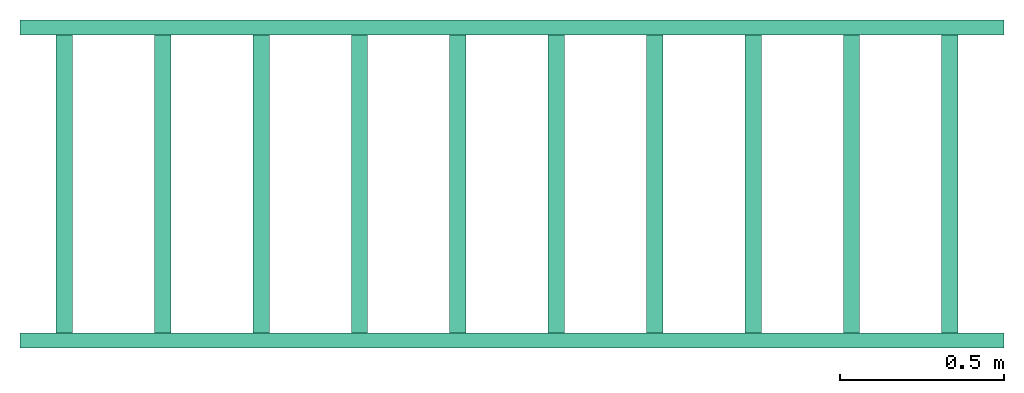
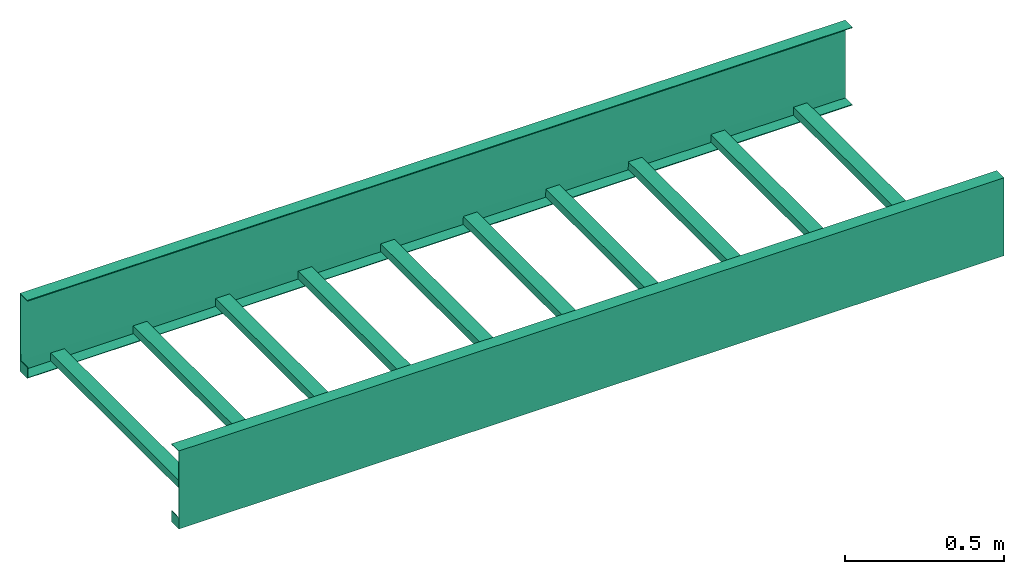
# One storey: 1 cable carrier segment.
"""IFC4 building model written with IfcOpenShell, lengths in millimetres."""

import ifcopenshell
import ifcopenshell.guid

model = None  # the IFC model being written
_history = None  # IfcOwnerHistory: only IFC2X3 demands one
_inside = {}  # id of a spatial element -> (the spatial element, [elements in it])
_under = {}  # id of a project, library or spatial element -> (it, [spatial elements below it])
_declared = {}  # id of a project -> (the project, [libraries it declares])
_typed = {}  # id of a type object -> (the type object, [elements of that type])
_made_of = {}  # id of a material, layer set ... -> (it, [elements and type objects made of it])


def new_model(schema):
    """Start an empty IFC model of exactly this schema.

    Asked for "IFC4X3", IfcOpenShell would pick the latest addendum, in which some entities
    have other attributes; the version numbers below select the first issue.
    IFC2X3 requires an IfcOwnerHistory on every rooted entity: one is made here for all.
    """
    global model, _history
    if schema == "IFC4X3":
        model = ifcopenshell.file(schema_version=(4, 3, 0, 0))
    else:
        model = ifcopenshell.file(schema=schema)
    _inside.clear()
    _under.clear()
    _declared.clear()
    _typed.clear()
    _made_of.clear()
    _history = None
    if model.schema == "IFC2X3":
        org = make("IfcOrganization", Name="unknown")
        user = make(
            "IfcPersonAndOrganization",
            ThePerson=make("IfcPerson", FamilyName="unknown"),
            TheOrganization=org,
        )
        app = make(
            "IfcApplication",
            ApplicationDeveloper=org,
            Version="unknown",
            ApplicationFullName="unknown",
            ApplicationIdentifier="unknown",
        )
        _history = make(
            "IfcOwnerHistory",
            OwningUser=user,
            OwningApplication=app,
            ChangeAction="ADDED",
            CreationDate=0,
        )
    return model


def make(cls, **values):
    """One entity of the class cls with the attributes given. An attribute that is None is left unset."""
    return model.create_entity(
        cls, **{name: value for name, value in values.items() if value is not None}
    )


def entity(cls, *values):
    """Any entity or typed value of the class cls, its attributes in the order of the schema. None: left unset."""
    e = model.create_entity(cls)
    for i, value in enumerate(values):
        if value is not None:
            e[i] = value
    return e


def rooted(cls, **values):
    """An entity with a GlobalId (a new one), such as an element, a storey or a relation."""
    return make(cls, GlobalId=ifcopenshell.guid.new(), OwnerHistory=_history, **values)


def si_unit(unit_type, name, prefix=None):
    """IfcSIUnit, for example si_unit("LENGTHUNIT", "METRE", prefix="MILLI")."""
    return make("IfcSIUnit", UnitType=unit_type, Prefix=prefix, Name=name)


def converted_unit(unit_type, name, factor, base, dimensions=None, offset=None):
    """IfcConversionBasedUnit, such as the inch: factor (a typed value) times the base unit."""
    return make(
        "IfcConversionBasedUnit"
        if offset is None
        else "IfcConversionBasedUnitWithOffset",
        ConversionOffset=offset,
        Dimensions=None
        if dimensions is None
        else entity("IfcDimensionalExponents", *dimensions),
        UnitType=unit_type,
        Name=name,
        ConversionFactor=make(
            "IfcMeasureWithUnit", ValueComponent=factor, UnitComponent=base
        ),
    )


def assignment(units):
    """IfcUnitAssignment: the units of a project."""
    return None if units is None else make("IfcUnitAssignment", Units=units)


def point(xyz):
    """IfcCartesianPoint."""
    return None if xyz is None else make("IfcCartesianPoint", Coordinates=xyz)


def direction(xyz):
    """IfcDirection."""
    return None if xyz is None else make("IfcDirection", DirectionRatios=xyz)


def frame(location, z_axis=None, x_axis=None):
    """IfcAxis2Placement3D, a coordinate frame: its origin and axes. An axis left out is left unset."""
    return make(
        "IfcAxis2Placement3D",
        Location=point(location),
        Axis=direction(z_axis),
        RefDirection=direction(x_axis),
    )


def frame_2d(location, x_axis=None):
    """IfcAxis2Placement2D, a coordinate frame in the plane: its origin and x axis."""
    return make(
        "IfcAxis2Placement2D", Location=point(location), RefDirection=direction(x_axis)
    )


def origin_with_axes():
    """The frame at (0, 0, 0) with the z axis (0, 0, 1) and the x axis (1, 0, 0) written out."""
    return frame((0.0, 0.0, 0.0), z_axis=(0.0, 0.0, 1.0), x_axis=(1.0, 0.0, 0.0))


def origin_2d_with_axis():
    """The frame at (0, 0) in the plane with the x axis (1, 0) written out."""
    return frame_2d((0.0, 0.0), x_axis=(1.0, 0.0))


def place(relative_to, where):
    """IfcLocalPlacement: puts the frame where relative to a parent placement (None: the world)."""
    return make(
        "IfcLocalPlacement", PlacementRelTo=relative_to, RelativePlacement=where
    )


def context(
    kind, dimensions, precision=None, world=None, true_north=None, identifier=None
):
    """IfcGeometricRepresentationContext, for example the 3D "Model" context."""
    return make(
        "IfcGeometricRepresentationContext",
        ContextIdentifier=identifier,
        ContextType=kind,
        CoordinateSpaceDimension=dimensions,
        Precision=precision,
        WorldCoordinateSystem=world,
        TrueNorth=true_north,
    )


def subcontext(parent, identifier, kind, view, scale=None):
    """IfcGeometricRepresentationSubContext, for example "Body" below "Model"."""
    return make(
        "IfcGeometricRepresentationSubContext",
        ContextIdentifier=identifier,
        ContextType=kind,
        ParentContext=parent,
        TargetScale=scale,
        TargetView=view,
    )


def project(units=None, contexts=None):
    """IfcProject with its units and contexts."""
    return rooted(
        "IfcProject",
        Name="project",
        RepresentationContexts=contexts,
        UnitsInContext=assignment(units),
    )


def spatial(cls, under=None, at=None, **own):
    """A site, building, storey or space (cls), placed at a placement, below another one or the project."""
    s = rooted(cls, ObjectPlacement=at, **own)
    if under is not None:
        _under.setdefault(under.id(), (under, []))[1].append(s)
    return s


def point_list(points):
    """IfcCartesianPointList2D or 3D."""
    cls = (
        "IfcCartesianPointList2D" if len(points[0]) == 2 else "IfcCartesianPointList3D"
    )
    return make(cls, CoordList=points)


def polygons(points, faces, closed=None, point_numbers=None):
    """IfcPolygonalFaceSet: a face is its outer loop, then its inner loops; points numbered from 1."""
    made = []
    for loops in faces:
        if len(loops) == 1:
            made.append(make("IfcIndexedPolygonalFace", CoordIndex=loops[0]))
        else:
            made.append(
                make(
                    "IfcIndexedPolygonalFaceWithVoids",
                    CoordIndex=loops[0],
                    InnerCoordIndices=loops[1:],
                )
            )
    return make(
        "IfcPolygonalFaceSet",
        Coordinates=point_list(points),
        Closed=closed,
        Faces=made,
        PnIndex=point_numbers,
    )


def shape(context_of_items, identifier, shape_type, items):
    """IfcShapeRepresentation: the items that make up one representation, for example the "Body"."""
    return make(
        "IfcShapeRepresentation",
        ContextOfItems=context_of_items,
        RepresentationIdentifier=identifier,
        RepresentationType=shape_type,
        Items=items,
    )


def source(mapping_origin, context_of_items, identifier, shape_type, items):
    """IfcRepresentationMap: a shape defined once, which mapped items show again and again."""
    return make(
        "IfcRepresentationMap",
        MappingOrigin=mapping_origin,
        MappedRepresentation=shape(context_of_items, identifier, shape_type, items),
    )


def transform(
    local_origin,
    x_axis=None,
    y_axis=None,
    z_axis=None,
    scale=None,
    scale2=None,
    scale3=None,
    uniform=True,
):
    """IfcCartesianTransformationOperator3D, or its non-uniform kind. x_axis, y_axis, z_axis: its Axis1, 2, 3."""
    if uniform:
        return make(
            "IfcCartesianTransformationOperator3D",
            Axis1=direction(x_axis),
            Axis2=direction(y_axis),
            LocalOrigin=point(local_origin),
            Scale=scale,
            Axis3=direction(z_axis),
        )
    return make(
        "IfcCartesianTransformationOperator3DnonUniform",
        Axis1=direction(x_axis),
        Axis2=direction(y_axis),
        LocalOrigin=point(local_origin),
        Scale=scale,
        Axis3=direction(z_axis),
        Scale2=scale2,
        Scale3=scale3,
    )


def mapped(mapping_source, mapping_target):
    """IfcMappedItem: shows the shape of a source again, moved by a transform."""
    return make(
        "IfcMappedItem", MappingSource=mapping_source, MappingTarget=mapping_target
    )


def made_of(thing, what):
    """Note that an element or type object is made of a material, layer set ...; save() writes the relation."""
    if what is not None:
        _made_of.setdefault(what.id(), (what, []))[1].append(thing)
    return thing


def type_object(cls, material=None, **own):
    """A type object (cls), such as IfcWallType, which elements share."""
    return made_of(rooted(cls, **own), material)


def type_shapes(of_type, sources):
    """Give a type object the sources (RepresentationMaps) that its elements show as mapped items."""
    of_type.RepresentationMaps = sources


def element(
    cls,
    number,
    at=None,
    inside=None,
    cuts=None,
    type_object=None,
    material=None,
    context=None,
    identifier="Body",
    shape_type=None,
    held_by="IfcProductDefinitionShape",
    body=None,
    shapes=None,
    **own,
):
    """One element of the class cls, such as IfcWall. Its Tag is "e" and its number.

    at: its placement. inside: the storey or other place that contains it. cuts: it is an
    opening in that element (IfcRelVoidsElement). A single representation is given by context,
    identifier, shape_type and body (its items); several are given by shapes. held_by: the class
    of the entity that holds the representations. save() writes the other relations.
    """
    e = rooted(cls, Tag="e%d" % number, ObjectPlacement=at, **own)
    if body is not None:
        shapes = [shape(context, identifier, shape_type, body)]
    if shapes is not None:
        e.Representation = make(held_by, Representations=shapes)
    if inside is not None:
        _inside.setdefault(inside.id(), (inside, []))[1].append(e)
    if cuts is not None:
        rooted(
            "IfcRelVoidsElement", RelatingBuildingElement=cuts, RelatedOpeningElement=e
        )
    if type_object is not None:
        _typed.setdefault(type_object.id(), (type_object, []))[1].append(e)
    return made_of(e, material)


def aggregate(whole, parts):
    """IfcRelAggregates: a whole, such as a stair, and the parts it consists of."""
    return rooted("IfcRelAggregates", RelatingObject=whole, RelatedObjects=parts)


def save(model, path):
    """Write the relations noted so far, then the file.

    IfcRelAggregates (storeys below a building ...), IfcRelContainedInSpatialStructure (elements
    in a storey), IfcRelDefinesByType, IfcRelAssociatesMaterial and IfcRelDeclares: one each for
    every whole, place, type object, material and project.
    """
    for whole, parts in _under.values():
        aggregate(whole, parts)
    for where, things in _inside.values():
        rooted(
            "IfcRelContainedInSpatialStructure",
            RelatedElements=things,
            RelatingStructure=where,
        )
    for kind, things in _typed.values():
        rooted("IfcRelDefinesByType", RelatedObjects=things, RelatingType=kind)
    for what, things in _made_of.values():
        rooted("IfcRelAssociatesMaterial", RelatedObjects=things, RelatingMaterial=what)
    for by, libraries in _declared.values():
        rooted("IfcRelDeclares", RelatingContext=by, RelatedDefinitions=libraries)
    model.write(path)


model = new_model("IFC4")

# Units and contexts
model_context = context("Model", 3, precision=1e-05, world=origin_with_axes())
plan_context = context("Plan", 2, precision=1e-05, world=origin_2d_with_axis())
body_context = subcontext(model_context, "Body", "Model", "MODEL_VIEW")
ifc_project = project(units=[si_unit("VOLUMEUNIT", "CUBIC_METRE"), si_unit("LENGTHUNIT", "METRE", prefix="MILLI"), converted_unit("PLANEANGLEUNIT", "degree", entity("IfcReal", 0.0174532925199433), si_unit("PLANEANGLEUNIT", "RADIAN"), dimensions=[0, 0, 0, 0, 0, 0, 0]), si_unit("AREAUNIT", "SQUARE_METRE")], contexts=[model_context, plan_context])

# Site, building, storey
site_placement = place(None, origin_with_axes())
site = spatial("IfcSite", under=ifc_project, at=site_placement)
building_placement = place(site_placement, origin_with_axes())
building = spatial("IfcBuilding", under=site, at=building_placement, Name="Building")
storey_placement = place(building_placement, origin_with_axes())
storey = spatial("IfcBuildingStorey", under=building, at=storey_placement, Name="Storey")

# Cable carrier segment
cable_carrier_segment_type = type_object("IfcCableCarrierSegmentType", Name="Cube", PredefinedType="CABLELADDERSEGMENT")
shared_shape = source(origin_with_axes(), body_context, "Body", "Tessellation", [
    polygons([(0.0, -999.999938964844, -2.98023205687059e-05), (0.0, -999.999938964844, 299.999969482422), (2999.99975585938, -999.999938964844, -2.98023205687059e-05), (2999.99975585938, -999.999938964844, 299.999969482422), (0.000119209282274824, -954.154174804688, -1.4901160284353e-05), (0.000119209282274824, -954.154174804688, 299.999938964844), (2999.99975585938, -954.154174804688, -1.4901160284353e-05), (2999.99975585938, -954.154174804688, 299.999938964844), (0.0, -999.999938964844, 42.8773231506348), (2999.99975585938, -999.999938964844, 42.8773231506348), (0.000119209282274824, -954.154174804688, 42.8773345947266), (1.73205304145813, -998.267883300781, 1.73202061653137), (0.0, -997.878601074219, 297.878631591797), (2999.99975585938, -997.878601074219, 2.12129068374634), (2999.99975585938, -997.878601074219, 297.878631591797), (2.12143802642822, -954.154174804688, 2.12130689620972), (0.000119209282274824, -954.154174804688, 296.999938964844), (2999.99975585938, -954.154174804688, 2.99998497962952), (2999.99975585938, -954.154174804688, 296.999938964844), (1.34164237976074, -997.316650390625, 42.8773231506348), (2999.99975585938, -996.999938964844, 42.8773231506348), (3.00011897087097, -954.154174804688, 42.8773345947266)], [[[10, 4, 2, 9]], [[5, 7, 3, 1]], [[8, 6, 2, 4]], [[1, 9, 11, 5]], [[3, 10, 9, 1]], [[21, 20, 13, 15]], [[16, 12, 14, 18]], [[19, 15, 13, 17]], [[12, 16, 22, 20]], [[14, 12, 20, 21]], [[9, 2, 13, 20]], [[8, 4, 15, 19]], [[10, 3, 14, 21]], [[2, 6, 17, 13]], [[3, 7, 18, 14]], [[6, 8, 19, 17]], [[7, 5, 16, 18]], [[5, 11, 22, 16]], [[4, 10, 21, 15]], [[11, 9, 20, 22]]]),
    polygons([(0.0, 0.0, -2.98023205687059e-05), (0.0, 0.0, 42.8773231506348), (2999.99975585938, 0.0, -2.98023205687059e-05), (0.000119209282274824, -45.845775604248, -1.4901160284353e-05), (2999.99975585938, -45.845775604248, -1.4901160284353e-05), (0.000119209282274824, -45.845775604248, 42.8773345947266), (2.12143802642822, -45.8457679748535, 2.12130689620972), (1.73205304145813, -1.73204863071442, 1.73202061653137), (2999.99975585938, -45.845775604248, 2.99998497962952), (3.00011897087097, -45.8457679748535, 42.8773345947266), (1.34164237976074, -2.68328046798706, 42.8773231506348), (0.0, -2.12132120132446, 297.878631591797), (2999.99975585938, -2.99999976158142, 42.8773231506348), (2999.99975585938, -2.12131977081299, 2.12129068374634), (2999.99975585938, -2.12131929397583, 297.878631591797), (2999.99975585938, 0.0, 42.8773231506348), (2999.99975585938, 0.0, 299.999969482422), (0.0, 0.0, 299.999969482422), (2999.99975585938, -45.845775604248, 299.999938964844), (0.000119209282274824, -45.845775604248, 299.999938964844), (2999.99975585938, -45.8457717895508, 296.999938964844), (0.000119209282274824, -45.8457717895508, 296.999938964844)], [[[4, 6, 2, 1]], [[1, 2, 16, 3]], [[1, 3, 5, 4]], [[4, 5, 9, 7]], [[6, 4, 7, 10]], [[7, 8, 11, 10]], [[8, 7, 9, 14]], [[2, 6, 10, 11]], [[8, 14, 13, 11]], [[18, 2, 11, 12]], [[11, 13, 15, 12]], [[3, 16, 13, 14]], [[16, 17, 15, 13]], [[2, 18, 17, 16]], [[17, 18, 20, 19]], [[17, 19, 21, 15]], [[19, 20, 22, 21]], [[15, 21, 22, 12]], [[20, 18, 12, 22]], [[5, 3, 14, 9]]]),
    polygons([(109.999984741211, -999.999938964844, 2.99999094009399), (109.999984741211, 0.0, 2.99999094009399), (109.999984741211, -999.999938964844, 32.9999885559082), (159.999984741211, -999.999938964844, 2.99999094009399), (159.999984741211, 0.0, 2.99999094009399), (159.999984741211, -999.999938964844, 32.9999885559082), (159.999984741211, 0.0, 32.9999885559082), (109.999984741211, 0.0, 32.9999885559082)], [[[2, 5, 4, 1]], [[1, 3, 8, 2]], [[4, 6, 3, 1]], [[5, 7, 6, 4]], [[7, 8, 3, 6]], [[2, 8, 7, 5]]]),
    polygons([(409.999969482422, -999.999938964844, 2.99999094009399), (409.999969482422, 0.0, 2.99999094009399), (409.999969482422, -999.999938964844, 32.9999885559082), (459.999969482422, -999.999938964844, 2.99999094009399), (459.999969482422, 0.0, 2.99999094009399), (459.999969482422, -999.999938964844, 32.9999885559082), (459.999969482422, 0.0, 32.9999885559082), (409.999969482422, 0.0, 32.9999885559082)], [[[2, 5, 4, 1]], [[1, 3, 8, 2]], [[4, 6, 3, 1]], [[5, 7, 6, 4]], [[7, 8, 3, 6]], [[2, 8, 7, 5]]]),
    polygons([(710.0, -999.999938964844, 2.99999094009399), (710.0, 0.0, 2.99999094009399), (710.0, -999.999938964844, 32.9999885559082), (759.999938964844, -999.999938964844, 2.99999094009399), (759.999938964844, 0.0, 2.99999094009399), (759.999938964844, -999.999938964844, 32.9999885559082), (759.999938964844, 0.0, 32.9999885559082), (710.0, 0.0, 32.9999885559082)], [[[2, 5, 4, 1]], [[1, 3, 8, 2]], [[4, 6, 3, 1]], [[5, 7, 6, 4]], [[7, 8, 3, 6]], [[2, 8, 7, 5]]]),
    polygons([(1009.99993896484, -999.999938964844, 2.99999094009399), (1009.99993896484, 0.0, 2.99999094009399), (1009.99993896484, -999.999938964844, 32.9999885559082), (1059.99987792969, -999.999938964844, 2.99999094009399), (1059.99987792969, 0.0, 2.99999094009399), (1059.99987792969, -999.999938964844, 32.9999885559082), (1059.99987792969, 0.0, 32.9999885559082), (1009.99993896484, 0.0, 32.9999885559082)], [[[2, 5, 4, 1]], [[1, 3, 8, 2]], [[4, 6, 3, 1]], [[5, 7, 6, 4]], [[7, 8, 3, 6]], [[2, 8, 7, 5]]]),
    polygons([(1310.0, -999.999938964844, 2.99999094009399), (1310.0, 0.0, 2.99999094009399), (1310.0, -999.999938964844, 32.9999885559082), (1359.99987792969, -999.999938964844, 2.99999094009399), (1359.99987792969, 0.0, 2.99999094009399), (1359.99987792969, -999.999938964844, 32.9999885559082), (1359.99987792969, 0.0, 32.9999885559082), (1310.0, 0.0, 32.9999885559082)], [[[2, 5, 4, 1]], [[1, 3, 8, 2]], [[4, 6, 3, 1]], [[5, 7, 6, 4]], [[7, 8, 3, 6]], [[2, 8, 7, 5]]]),
    polygons([(1609.99987792969, -999.999938964844, 2.99999094009399), (1609.99987792969, 0.0, 2.99999094009399), (1609.99987792969, -999.999938964844, 32.9999885559082), (1659.99987792969, -999.999938964844, 2.99999094009399), (1659.99987792969, 0.0, 2.99999094009399), (1659.99987792969, -999.999938964844, 32.9999885559082), (1659.99987792969, 0.0, 32.9999885559082), (1609.99987792969, 0.0, 32.9999885559082)], [[[2, 5, 4, 1]], [[1, 3, 8, 2]], [[4, 6, 3, 1]], [[5, 7, 6, 4]], [[7, 8, 3, 6]], [[2, 8, 7, 5]]]),
    polygons([(1909.99987792969, -999.999938964844, 2.99999094009399), (1909.99987792969, 0.0, 2.99999094009399), (1909.99987792969, -999.999938964844, 32.9999885559082), (1959.99975585938, -999.999938964844, 2.99999094009399), (1959.99975585938, 0.0, 2.99999094009399), (1959.99975585938, -999.999938964844, 32.9999885559082), (1959.99975585938, 0.0, 32.9999885559082), (1909.99987792969, 0.0, 32.9999885559082)], [[[2, 5, 4, 1]], [[1, 3, 8, 2]], [[4, 6, 3, 1]], [[5, 7, 6, 4]], [[7, 8, 3, 6]], [[2, 8, 7, 5]]]),
    polygons([(2209.99975585938, -999.999938964844, 2.99999094009399), (2209.99975585938, 0.0, 2.99999094009399), (2209.99975585938, -999.999938964844, 32.9999885559082), (2259.99975585938, -999.999938964844, 2.99999094009399), (2259.99975585938, 0.0, 2.99999094009399), (2259.99975585938, -999.999938964844, 32.9999885559082), (2259.99975585938, 0.0, 32.9999885559082), (2209.99975585938, 0.0, 32.9999885559082)], [[[2, 5, 4, 1]], [[1, 3, 8, 2]], [[4, 6, 3, 1]], [[5, 7, 6, 4]], [[7, 8, 3, 6]], [[2, 8, 7, 5]]]),
    polygons([(2509.99951171875, -999.999938964844, 2.99999094009399), (2509.99951171875, 0.0, 2.99999094009399), (2509.99951171875, -999.999938964844, 32.9999885559082), (2559.99975585938, -999.999938964844, 2.99999094009399), (2559.99975585938, 0.0, 2.99999094009399), (2559.99975585938, -999.999938964844, 32.9999885559082), (2559.99975585938, 0.0, 32.9999885559082), (2509.99951171875, 0.0, 32.9999885559082)], [[[2, 5, 4, 1]], [[1, 3, 8, 2]], [[4, 6, 3, 1]], [[5, 7, 6, 4]], [[7, 8, 3, 6]], [[2, 8, 7, 5]]]),
    polygons([(2809.99951171875, -999.999938964844, 2.99999094009399), (2809.99951171875, 0.0, 2.99999094009399), (2809.99951171875, -999.999938964844, 32.9999885559082), (2859.99975585938, -999.999938964844, 2.99999094009399), (2859.99975585938, 0.0, 2.99999094009399), (2859.99975585938, -999.999938964844, 32.9999885559082), (2859.99975585938, 0.0, 32.9999885559082), (2809.99951171875, 0.0, 32.9999885559082)], [[[2, 5, 4, 1]], [[1, 3, 8, 2]], [[4, 6, 3, 1]], [[5, 7, 6, 4]], [[7, 8, 3, 6]], [[2, 8, 7, 5]]]),
])
type_shapes(cable_carrier_segment_type, [shared_shape])
cable_carrier_segment_placement = place(storey_placement, origin_with_axes())
element("IfcCableCarrierSegment", 1, at=cable_carrier_segment_placement, inside=storey, type_object=cable_carrier_segment_type, Name="CableCarrierSegment", context=body_context, shape_type="MappedRepresentation", body=[
    mapped(shared_shape, transform((0.0, 0.0, 0.0), x_axis=(1.0, 0.0, 0.0), y_axis=(0.0, 1.0, 0.0), z_axis=(0.0, 0.0, 1.0), scale=1.0)),
])

save(model, "model.ifc")
